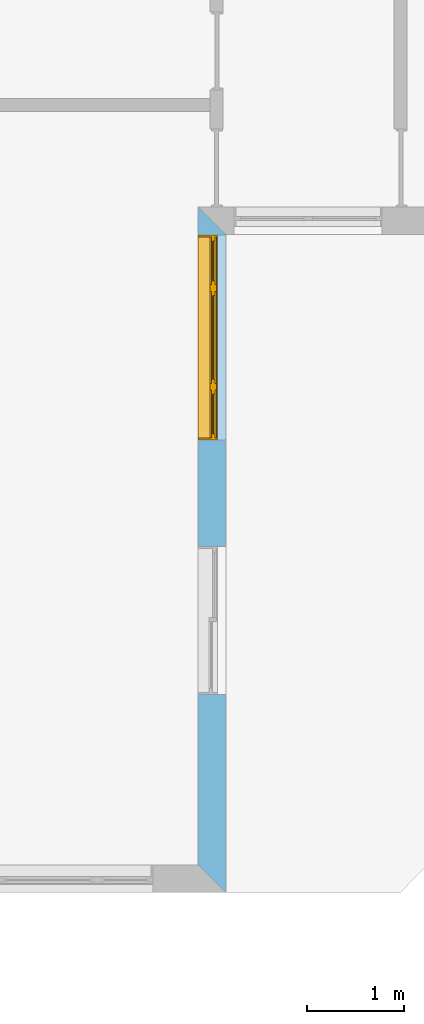
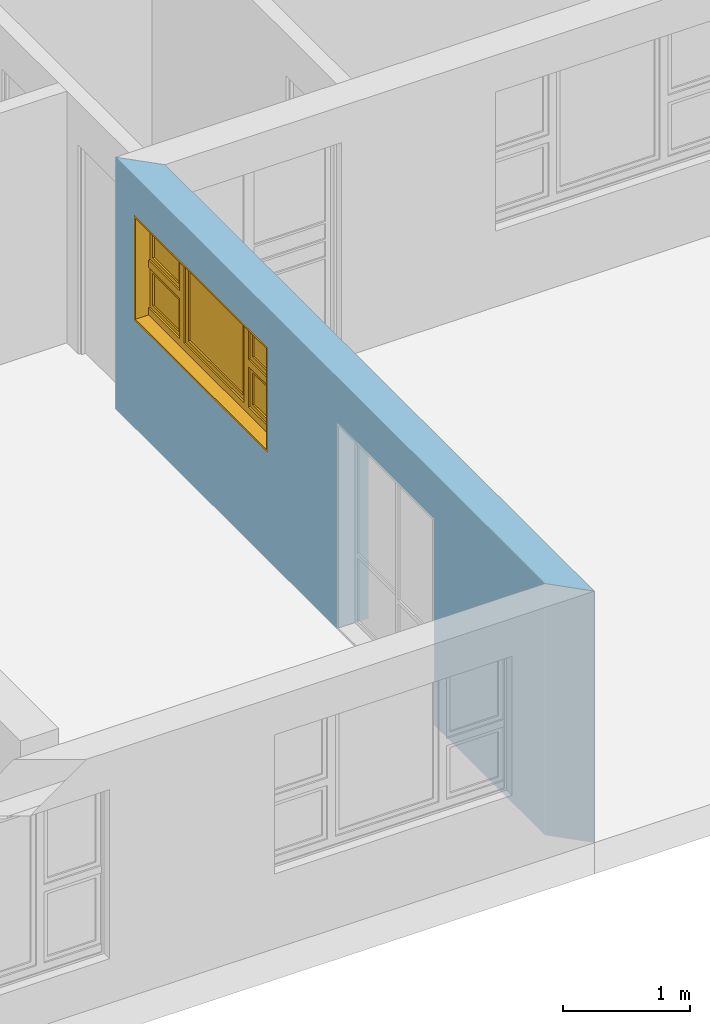
# One storey, part 10 of 15: 1 window, 2 openings, plus 1 element that does not belong to this part.
"""IFC4 building model written with IfcOpenShell, lengths in millimetres."""

from ifc_helpers import new_model, entity, si_unit, converted_unit, frame, origin_with_axes, origin_2d_with_axis, place, context, subcontext, project, spatial, line, indexed_curve, outline, extrude, clip, halfspace, polygons, source, transform, mapped, material, layer, layer_set, layer_usage, type_object, type_shapes, element, fill, save


model = new_model("IFC4")

# Units and contexts
model_context = context("Model", 3, precision=1e-05, world=origin_with_axes())
plan_context = context("Plan", 2, precision=1e-05, world=origin_2d_with_axis())
body_context = subcontext(model_context, "Body", "Model", "MODEL_VIEW")
ifc_project = project(units=[si_unit("VOLUMEUNIT", "CUBIC_METRE"), si_unit("LENGTHUNIT", "METRE", prefix="MILLI"), converted_unit("PLANEANGLEUNIT", "degree", entity("IfcReal", 0.0174532925199433), si_unit("PLANEANGLEUNIT", "RADIAN"), dimensions=[0, 0, 0, 0, 0, 0, 0]), si_unit("AREAUNIT", "SQUARE_METRE")], contexts=[model_context, plan_context])

# Site, building, storey
site_placement = place(None, origin_with_axes())
site = spatial("IfcSite", under=ifc_project, at=site_placement)
building_placement = place(site_placement, origin_with_axes())
building = spatial("IfcBuilding", under=site, at=building_placement, Name="Building")
storey_placement = place(building_placement, origin_with_axes())
storey = spatial("IfcBuildingStorey", under=building, at=storey_placement, Name="EXISTING")

# Wall, openings, window
ifc_material = material()
ifc_layer = layer(ifc_material, 285.0, Name="brick")
ifc_layer_set = layer_set([ifc_layer])
ifc_layer_usage = layer_usage(ifc_layer_set, "AXIS2", "POSITIVE", 0.0)
wall_type = type_object("IfcWallType", Name="285mm Wall", PredefinedType="STANDARD", material=ifc_layer_set)
wall_placement = place(storey_placement, frame((13494.119644165, -4518.33248138428, 0.0), z_axis=(0.0, 0.0, 1.0), x_axis=(3.13916473260163e-07, 0.999999999999951, 0.0)))
wall = element("IfcWall", 1, at=wall_placement, inside=storey, type_object=wall_type, material=ifc_layer_usage, Name="Wall", context=body_context, shape_type="Clipping", body=[
    clip(clip(extrude(outline(indexed_curve([(0.0, 0.0), (0.0, 285.0), (7060.00143769791, 285.0), (7060.00143769791, 0.0), (0.0, 0.0)], self_intersect=False)), origin_with_axes(), (0.0, 0.0, 1.0), 2425.00019073486), halfspace(frame((2.32475940720178e-05, 5.74426053390198e-05, 0.0), z_axis=(-0.707106709480286, 0.707106828689575, 0.0), x_axis=(0.707106840791191, 0.707106721581899, 0.0)), False)), halfspace(frame((6775.00104904175, 0.000276878381555434, 0.0), z_axis=(0.70710700750351, -0.707106530666351, 0.0), x_axis=(-0.707106542767924, -0.70710701960509, 0.0)), False)),
])
shared_shape_1 = source(origin_with_axes(), body_context, "Body", "SweptSolid", [
    extrude(outline(indexed_curve([(0.0, 0.0), (2110.00024414062, 0.0), (2110.00024414062, 1014.99993896484), (0.0, 1014.99993896484)], segments=[line(1, 2, 3, 4, 1)])), frame((1.19209282445354e-07, -600.0, 0.0), z_axis=(0.0, -1.0, 0.0), x_axis=(1.0, 0.0, 0.0)), (0.0, 0.0, -1.0), 1200.0),
])
opening_1_placement = place(wall_placement, frame((6771.17128867833, 136.111477694053, 1030.00009059906), z_axis=(0.0, 0.0, 1.0), x_axis=(-0.999999999999999, -3.17864987664478e-08, 0.0)))
opening_1 = element("IfcOpeningElement", 2, at=opening_1_placement, cuts=wall, PredefinedType="OPENING", context=body_context, shape_type="MappedRepresentation", body=[
    mapped(shared_shape_1, transform((0.0, 0.0, 0.0), x_axis=(1.0, 0.0, 0.0), y_axis=(0.0, 1.0, 0.0), z_axis=(0.0, 0.0, 1.0), scale=1.0)),
])
shared_shape_2 = source(origin_with_axes(), body_context, "Body", "SweptSolid", [
    extrude(outline(indexed_curve([(0.0, 0.0), (1525.00085449219, 0.0), (1525.00085449219, 1990.0), (0.0, 1990.0)], segments=[line(1, 2, 3, 4, 1)])), frame((-3.57627840230634e-07, -600.0, 0.0), z_axis=(0.0, -1.0, 0.0), x_axis=(1.0, 0.0, 0.0)), (0.0, 0.0, -1.0), 1200.0),
])
opening_2_placement = place(wall_placement, frame((3565.00013056336, 146.110700105945, 0.0), z_axis=(0.0, 0.0, 1.0), x_axis=(-0.999999999999999, -3.17864987664478e-08, 0.0)))
element("IfcOpeningElement", 3, at=opening_2_placement, cuts=wall, PredefinedType="OPENING", context=body_context, shape_type="MappedRepresentation", body=[
    mapped(shared_shape_2, transform((0.0, 0.0, 0.0), x_axis=(1.0, 0.0, 0.0), y_axis=(0.0, 1.0, 0.0), z_axis=(0.0, 0.0, 1.0), scale=1.0)),
])
window_type = type_object("IfcWindowType", Name="Ex.2110x1015", PartitioningType="NOTDEFINED", PredefinedType="WINDOW")
shared_shape_3 = source(origin_with_axes(), body_context, "Body", "Tessellation", [
    polygons([(2110.00048828125, -148.888916015625, 0.0), (2110.00048828125, -148.888916015625, 19.999979019165), (0.00107288348954171, -148.889038085938, 0.0), (0.00107288348954171, -148.889038085938, 19.999979019165), (2110.00048828125, 51.1110572814941, 0.0), (2110.00048828125, 51.1110572814941, 19.999979019165), (0.00107288348954171, 51.1110000610352, 0.0), (0.00107288348954171, 51.1110000610352, 19.999979019165), (2109.99951171875, -148.888916015625, 994.999694824219), (2109.99951171875, -148.888916015625, 1014.99993896484), (0.000119209282274824, -148.889038085938, 994.999694824219), (0.000119209282274824, -148.889038085938, 1014.99993896484), (2109.99951171875, 51.1110572814941, 994.999694824219), (2109.99951171875, 51.1110572814941, 1014.99993896484), (0.000119209282274824, 51.1110000610352, 994.999694824219), (0.000119209282274824, 51.1110000610352, 1014.99993896484), (0.000119209282274824, -148.888916015625, 20.0000400543213), (19.9996223449707, -148.888916015625, 20.0000400543213), (0.000119209282274824, -148.889038085938, 994.999694824219), (19.9996223449707, -148.889038085938, 994.999694824219), (0.000119209282274824, 51.1110572814941, 20.0000400543213), (19.9996223449707, 51.1110572814941, 20.0000400543213), (0.000119209282274824, 51.1110000610352, 994.999694824219), (19.9996223449707, 51.1110000610352, 994.999694824219), (2090.0, -148.888916015625, 20.0000400543213), (2109.99951171875, -148.888916015625, 20.0000400543213), (2090.0, -148.889038085938, 994.999694824219), (2109.99951171875, -148.889038085938, 994.999694824219), (2090.0, 51.1110572814941, 20.0000400543213), (2109.99951171875, 51.1111183166504, 20.0000400543213), (2090.0, 51.1110000610352, 994.999694824219), (2109.99951171875, 51.1110000610352, 994.999694824219), (1527.49926757812, -28.8889198303223, 20.0000400543213), (1597.49987792969, -28.8889198303223, 20.0000400543213), (1527.49926757812, -28.8889198303223, 994.999694824219), (1597.49987792969, -28.8889198303223, 994.999694824219), (1527.49926757812, 41.1110687255859, 20.0000400543213), (1597.49987792969, 41.1110687255859, 20.0000400543213), (1527.49926757812, 41.1110076904297, 994.999694824219), (1597.49987792969, 41.1110076904297, 994.999694824219), (512.500854492188, -28.8889198303223, 20.0000400543213), (582.500549316406, -28.8889198303223, 20.0000400543213), (512.500854492188, -28.8889198303223, 994.999694824219), (582.500549316406, -28.8889198303223, 994.999694824219), (512.500854492188, 41.1110687255859, 20.0000400543213), (582.500549316406, 41.1110687255859, 20.0000400543213), (512.500854492188, 41.1110076904297, 994.999694824219), (582.500549316406, 41.1110076904297, 994.999694824219), (19.9986686706543, -28.8890399932861, 549.998107910156), (19.9986686706543, -28.8889808654785, 479.998718261719), (512.499877929688, -28.8889198303223, 549.998840332031), (512.499877929688, -28.8889198303223, 479.999420166016), (19.9986686706543, 41.1109504699707, 549.998107910156), (19.9986686706543, 41.1110076904297, 479.998718261719), (512.499877929688, 41.1110687255859, 549.998840332031), (512.499877929688, 41.1110687255859, 479.999420166016), (1597.49987792969, -28.8890399932861, 549.998107910156), (1597.49987792969, -28.8889808654785, 479.998718261719), (2089.9990234375, -28.8889198303223, 549.998840332031), (2089.9990234375, -28.8889198303223, 479.999420166016), (1597.49987792969, 41.1109504699707, 549.998107910156), (1597.49987792969, 41.1110076904297, 479.998718261719), (2089.9990234375, 41.1110687255859, 549.998840332031), (2089.9990234375, 41.1110687255859, 479.999420166016), (1597.49987792969, -13.8889951705933, 994.999694824219), (1597.49987792969, -13.8889951705933, 955.0), (2089.9990234375, -13.8889360427856, 995.000183105469), (2089.9990234375, -13.8889360427856, 955.000671386719), (1597.49987792969, 26.1109638214111, 994.999694824219), (1597.49987792969, 26.1109638214111, 955.000244140625), (2089.9990234375, 26.1110229492188, 995.000183105469), (2089.9990234375, 26.111083984375, 955.000671386719), (1597.49987792969, -13.8889951705933, 589.997863769531), (1597.49987792969, -13.8889951705933, 549.998229980469), (2089.9990234375, -13.8889360427856, 589.998474121094), (2089.9990234375, -13.8889360427856, 549.998718261719), (1597.49987792969, 26.1109638214111, 589.997863769531), (1597.49987792969, 26.1109638214111, 549.998229980469), (2089.9990234375, 26.1110229492188, 589.998474121094), (2089.9990234375, 26.111083984375, 549.998718261719), (1637.49987792969, -13.8889360427856, 955.000244140625), (1597.50085449219, -13.8889360427856, 955.000244140625), (1637.49987792969, -13.8889360427856, 589.998474121094), (1597.50085449219, -13.8889360427856, 589.998474121094), (1637.49987792969, 26.1110229492188, 955.000244140625), (1597.50085449219, 26.1110229492188, 955.000244140625), (1637.49987792969, 26.111083984375, 589.998474121094), (1597.50085449219, 26.111083984375, 589.998474121094), (2089.9990234375, -13.8889360427856, 955.000244140625), (2050.0, -13.8889360427856, 955.000244140625), (2089.9990234375, -13.8889360427856, 589.998474121094), (2050.0, -13.8889360427856, 589.998474121094), (2089.9990234375, 26.1110229492188, 955.000244140625), (2050.0, 26.1110229492188, 955.000244140625), (2089.9990234375, 26.111083984375, 589.998474121094), (2050.0, 26.111083984375, 589.998474121094), (19.9986686706543, -13.8889951705933, 994.999694824219), (19.9986686706543, -13.8889951705933, 955.0), (512.499877929688, -13.8889360427856, 995.000183105469), (512.499877929688, -13.8889360427856, 955.000671386719), (19.9986686706543, 26.1109638214111, 994.999694824219), (19.9986686706543, 26.1109638214111, 955.000244140625), (512.499877929688, 26.1110229492188, 995.000183105469), (512.499877929688, 26.111083984375, 955.000671386719), (19.9986686706543, -13.8889951705933, 589.997863769531), (19.9986686706543, -13.8889951705933, 549.998229980469), (512.499877929688, -13.8889360427856, 589.998474121094), (512.499877929688, -13.8889360427856, 549.998718261719), (19.9986686706543, 26.1109638214111, 589.997863769531), (19.9986686706543, 26.1109638214111, 549.998229980469), (512.499877929688, 26.1110229492188, 589.998474121094), (512.499877929688, 26.111083984375, 549.998718261719), (60.0005340576172, -13.8889360427856, 955.000244140625), (20.0005760192871, -13.8889360427856, 955.000244140625), (60.0005340576172, -13.8889360427856, 589.998474121094), (20.0005760192871, -13.8889360427856, 589.998474121094), (60.0005340576172, 26.1110229492188, 955.000244140625), (20.0005760192871, 26.1110229492188, 955.000244140625), (60.0005340576172, 26.111083984375, 589.998474121094), (20.0005760192871, 26.111083984375, 589.998474121094), (512.500854492188, -13.8889360427856, 955.000244140625), (472.500885009766, -13.8889360427856, 955.000244140625), (512.500854492188, -13.8889360427856, 589.998474121094), (472.500885009766, -13.8889360427856, 589.998474121094), (512.500854492188, 26.1110229492188, 955.000244140625), (472.500885009766, 26.1110229492188, 955.000244140625), (512.500854492188, 26.111083984375, 589.998474121094), (472.500885009766, 26.111083984375, 589.998474121094), (19.9986686706543, -28.8890399932861, 89.9991912841797), (19.9986686706543, -28.8889808654785, 19.9997711181641), (512.499877929688, -28.8889198303223, 89.9999694824219), (512.499877929688, -28.8889198303223, 20.000545501709), (19.9986686706543, 41.1109504699707, 89.9991912841797), (19.9986686706543, 41.1110076904297, 19.9997711181641), (512.499877929688, 41.1110687255859, 90.0000305175781), (512.499877929688, 41.1110687255859, 20.0005760192871), (1597.49987792969, -28.8890399932861, 89.9991912841797), (1597.49987792969, -28.8889808654785, 19.9997711181641), (2089.9990234375, -28.8889198303223, 89.9999694824219), (2089.9990234375, -28.8889198303223, 20.000545501709), (1597.49987792969, 41.1109504699707, 89.9991912841797), (1597.49987792969, 41.1110076904297, 19.9997711181641), (2089.9990234375, 41.1110687255859, 90.0000305175781), (2089.9990234375, 41.1110687255859, 20.0005760192871), (582.499572753906, -28.8890399932861, 89.9991912841797), (582.499572753906, -28.8889808654785, 19.9997711181641), (1527.49926757812, -28.8889198303223, 89.9999694824219), (1527.49926757812, -28.8889198303223, 20.000545501709), (582.499572753906, 41.1109504699707, 89.9991912841797), (582.499572753906, 41.1110076904297, 19.9997711181641), (1527.49926757812, 41.1110687255859, 90.0000305175781), (1527.49926757812, 41.1110687255859, 20.0005760192871), (1597.49987792969, -13.8889951705933, 479.998931884766), (1597.49987792969, -13.8889951705933, 439.999237060547), (2089.9990234375, -13.8889360427856, 479.999420166016), (2089.9990234375, -13.8889360427856, 439.999816894531), (1597.49987792969, 26.1109638214111, 479.998931884766), (1597.49987792969, 26.1109638214111, 439.999237060547), (2089.9990234375, 26.1110229492188, 479.999420166016), (2089.9990234375, 26.111083984375, 439.999816894531), (1597.49987792969, -13.8889951705933, 129.999694824219), (1597.49987792969, -13.8889951705933, 90.0000305175781), (2089.9990234375, -13.8889360427856, 130.000228881836), (2089.9990234375, -13.8889360427856, 90.0005035400391), (1597.49987792969, 26.1109638214111, 129.999694824219), (1597.49987792969, 26.1109638214111, 90.0000305175781), (2089.9990234375, 26.1110229492188, 130.000228881836), (2089.9990234375, 26.111083984375, 90.0005645751953), (1637.49987792969, -13.8889360427856, 439.999816894531), (1597.50085449219, -13.8889360427856, 439.999816894531), (1637.49987792969, -13.8889360427856, 129.999099731445), (1597.50085449219, -13.8889360427856, 129.999145507812), (1637.49987792969, 26.1110229492188, 439.999816894531), (1597.50085449219, 26.1110229492188, 439.999816894531), (1637.49987792969, 26.111083984375, 129.999099731445), (1597.50085449219, 26.111083984375, 129.999145507812), (2089.9990234375, -13.8889360427856, 439.999816894531), (2050.0, -13.8889360427856, 439.999938964844), (2089.9990234375, -13.8889360427856, 129.999099731445), (2050.0, -13.8889360427856, 129.999145507812), (2089.9990234375, 26.1110229492188, 439.999816894531), (2050.0, 26.1110229492188, 439.999938964844), (2089.9990234375, 26.111083984375, 129.999099731445), (2050.0, 26.111083984375, 129.999145507812), (19.9986686706543, -13.8889951705933, 479.998931884766), (19.9986686706543, -13.8889951705933, 439.999237060547), (512.499877929688, -13.8889360427856, 479.999420166016), (512.499877929688, -13.8889360427856, 439.999816894531), (19.9986686706543, 26.1109638214111, 479.998931884766), (19.9986686706543, 26.1109638214111, 439.999237060547), (512.499877929688, 26.1110229492188, 479.999420166016), (512.499877929688, 26.111083984375, 439.999816894531), (19.9986686706543, -13.8889951705933, 129.998611450195), (19.9986686706543, -13.8889951705933, 89.9989547729492), (512.499877929688, -13.8889360427856, 129.999145507812), (512.499877929688, -13.8889360427856, 89.9994354248047), (19.9986686706543, 26.1109638214111, 129.998611450195), (19.9986686706543, 26.1109638214111, 89.9989547729492), (512.499877929688, 26.1110229492188, 129.999145507812), (512.499877929688, 26.111083984375, 89.9994888305664), (60.0005340576172, -13.8889360427856, 439.999816894531), (20.0005760192871, -13.8889360427856, 439.999938964844), (60.0005340576172, -13.8889360427856, 129.999099731445), (20.0005760192871, -13.8889360427856, 129.999145507812), (60.0005340576172, 26.1110229492188, 439.999816894531), (20.0005760192871, 26.1110229492188, 439.999938964844), (60.0005340576172, 26.111083984375, 129.999099731445), (20.0005760192871, 26.111083984375, 129.999145507812), (512.500854492188, -13.8889360427856, 439.999816894531), (472.500885009766, -13.8889360427856, 439.999816894531), (512.500854492188, -13.8889360427856, 129.999099731445), (472.500885009766, -13.8889360427856, 129.999145507812), (512.500854492188, 26.1110229492188, 439.999816894531), (472.500885009766, 26.1110229492188, 439.999816894531), (512.500854492188, 26.111083984375, 129.999099731445), (472.500885009766, 26.111083984375, 129.999145507812), (582.499572753906, -13.8889951705933, 994.999694824219), (582.499572753906, -13.8889951705933, 955.0), (1527.49926757812, -13.8889360427856, 995.000183105469), (1527.49926757812, -13.8889360427856, 955.000671386719), (582.499572753906, 26.1109638214111, 994.999694824219), (582.499572753906, 26.1109638214111, 955.000244140625), (1527.49926757812, 26.111083984375, 995.000183105469), (1527.49926757812, 26.111083984375, 955.000671386719), (582.499572753906, -13.8889951705933, 129.998916625977), (582.499572753906, -13.8889951705933, 89.9991912841797), (1527.49926757812, -13.8889360427856, 129.999450683594), (1527.49926757812, -13.8889360427856, 89.9997863769531), (582.499572753906, 26.1109638214111, 129.998916625977), (582.499572753906, 26.1109638214111, 89.9992523193359), (1527.49926757812, 26.111083984375, 129.999450683594), (1527.49926757812, 26.111083984375, 89.9997863769531), (622.50146484375, -13.8889360427856, 955.000244140625), (582.50146484375, -13.8889360427856, 955.000244140625), (622.50146484375, -13.8889360427856, 129.999694824219), (582.50146484375, -13.8889360427856, 129.999694824219), (622.50146484375, 26.1110229492188, 955.000244140625), (582.50146484375, 26.1110229492188, 955.000244140625), (622.50146484375, 26.111083984375, 129.999694824219), (582.50146484375, 26.111083984375, 129.999694824219), (1527.49926757812, -13.8889360427856, 955.000244140625), (1487.50024414062, -13.8889360427856, 955.000244140625), (1527.49926757812, -13.8889360427856, 129.999633789062), (1487.50024414062, -13.8889360427856, 129.999633789062), (1527.49926757812, 26.1110229492188, 955.000244140625), (1487.50024414062, 26.1110229492188, 955.000244140625), (1527.49926757812, 26.111083984375, 129.999633789062), (1487.50024414062, 26.111083984375, 129.999633789062), (1487.50122070312, 1.11104917526245, 955.000244140625), (622.502380371094, 1.11104917526245, 955.000244140625), (1487.50122070312, 1.11104917526245, 129.999633789062), (622.502380371094, 1.11104917526245, 129.999694824219), (1487.50122070312, 11.1110391616821, 955.000244140625), (622.502380371094, 11.1110391616821, 955.000244140625), (1487.50122070312, 11.1110391616821, 129.999633789062), (622.502380371094, 11.1110391616821, 129.999694824219), (2049.9990234375, 1.11104917526245, 955.000244140625), (1637.49987792969, 1.11104917526245, 955.000244140625), (2049.9990234375, 1.11104917526245, 589.998901367188), (1637.49987792969, 1.11104917526245, 589.998901367188), (2049.9990234375, 11.1110391616821, 955.000244140625), (1637.49987792969, 11.1110391616821, 955.000244140625), (2049.9990234375, 11.1110391616821, 589.998901367188), (1637.49987792969, 11.1110391616821, 589.998901367188), (2049.9990234375, 1.11104917526245, 439.999694824219), (1637.49987792969, 1.11104917526245, 439.999816894531), (2049.9990234375, 1.11104917526245, 130.000518798828), (1637.49987792969, 1.11104917526245, 130.000579833984), (2049.9990234375, 11.1110391616821, 439.999694824219), (1637.49987792969, 11.1110391616821, 439.999816894531), (2049.9990234375, 11.1110391616821, 130.000518798828), (1637.49987792969, 11.1110391616821, 130.000579833984), (472.499938964844, 1.11104917526245, 955.000244140625), (60.0005340576172, 1.11104917526245, 955.000244140625), (472.499938964844, 1.11104917526245, 589.998901367188), (60.0005340576172, 1.11104917526245, 589.998901367188), (472.499938964844, 11.1110391616821, 955.000244140625), (60.0005340576172, 11.1110391616821, 955.000244140625), (472.499938964844, 11.1110391616821, 589.998901367188), (60.0005340576172, 11.1110391616821, 589.998901367188), (472.499938964844, 1.11104917526245, 439.999694824219), (60.0005340576172, 1.11104917526245, 439.999694824219), (472.499938964844, 1.11104917526245, 130.000518798828), (60.0005340576172, 1.11104917526245, 130.000579833984), (472.499938964844, 11.1110391616821, 439.999694824219), (60.0005340576172, 11.1110391616821, 439.999694824219), (472.499938964844, 11.1110391616821, 130.000518798828), (60.0005340576172, 11.1110391616821, 130.000579833984)], [[[1, 2, 4, 3]], [[3, 4, 8, 7]], [[7, 8, 6, 5]], [[5, 6, 2, 1]], [[3, 7, 5, 1]], [[8, 4, 2, 6]], [[9, 10, 12, 11]], [[11, 12, 16, 15]], [[15, 16, 14, 13]], [[13, 14, 10, 9]], [[11, 15, 13, 9]], [[16, 12, 10, 14]], [[17, 18, 20, 19]], [[19, 20, 24, 23]], [[23, 24, 22, 21]], [[21, 22, 18, 17]], [[19, 23, 21, 17]], [[24, 20, 18, 22]], [[25, 26, 28, 27]], [[27, 28, 32, 31]], [[31, 32, 30, 29]], [[29, 30, 26, 25]], [[27, 31, 29, 25]], [[32, 28, 26, 30]], [[33, 34, 36, 35]], [[35, 36, 40, 39]], [[39, 40, 38, 37]], [[37, 38, 34, 33]], [[35, 39, 37, 33]], [[40, 36, 34, 38]], [[41, 42, 44, 43]], [[43, 44, 48, 47]], [[47, 48, 46, 45]], [[45, 46, 42, 41]], [[43, 47, 45, 41]], [[48, 44, 42, 46]], [[49, 50, 52, 51]], [[51, 52, 56, 55]], [[55, 56, 54, 53]], [[53, 54, 50, 49]], [[51, 55, 53, 49]], [[56, 52, 50, 54]], [[57, 58, 60, 59]], [[59, 60, 64, 63]], [[63, 64, 62, 61]], [[61, 62, 58, 57]], [[59, 63, 61, 57]], [[64, 60, 58, 62]], [[65, 66, 68, 67]], [[67, 68, 72, 71]], [[71, 72, 70, 69]], [[69, 70, 66, 65]], [[67, 71, 69, 65]], [[72, 68, 66, 70]], [[73, 74, 76, 75]], [[75, 76, 80, 79]], [[79, 80, 78, 77]], [[77, 78, 74, 73]], [[75, 79, 77, 73]], [[80, 76, 74, 78]], [[81, 82, 84, 83]], [[83, 84, 88, 87]], [[87, 88, 86, 85]], [[85, 86, 82, 81]], [[83, 87, 85, 81]], [[88, 84, 82, 86]], [[89, 90, 92, 91]], [[91, 92, 96, 95]], [[95, 96, 94, 93]], [[93, 94, 90, 89]], [[91, 95, 93, 89]], [[96, 92, 90, 94]], [[97, 98, 100, 99]], [[99, 100, 104, 103]], [[103, 104, 102, 101]], [[101, 102, 98, 97]], [[99, 103, 101, 97]], [[104, 100, 98, 102]], [[105, 106, 108, 107]], [[107, 108, 112, 111]], [[111, 112, 110, 109]], [[109, 110, 106, 105]], [[107, 111, 109, 105]], [[112, 108, 106, 110]], [[113, 114, 116, 115]], [[115, 116, 120, 119]], [[119, 120, 118, 117]], [[117, 118, 114, 113]], [[115, 119, 117, 113]], [[120, 116, 114, 118]], [[121, 122, 124, 123]], [[123, 124, 128, 127]], [[127, 128, 126, 125]], [[125, 126, 122, 121]], [[123, 127, 125, 121]], [[128, 124, 122, 126]], [[129, 130, 132, 131]], [[131, 132, 136, 135]], [[135, 136, 134, 133]], [[133, 134, 130, 129]], [[131, 135, 133, 129]], [[136, 132, 130, 134]], [[137, 138, 140, 139]], [[139, 140, 144, 143]], [[143, 144, 142, 141]], [[141, 142, 138, 137]], [[139, 143, 141, 137]], [[144, 140, 138, 142]], [[145, 146, 148, 147]], [[147, 148, 152, 151]], [[151, 152, 150, 149]], [[149, 150, 146, 145]], [[147, 151, 149, 145]], [[152, 148, 146, 150]], [[153, 154, 156, 155]], [[155, 156, 160, 159]], [[159, 160, 158, 157]], [[157, 158, 154, 153]], [[155, 159, 157, 153]], [[160, 156, 154, 158]], [[161, 162, 164, 163]], [[163, 164, 168, 167]], [[167, 168, 166, 165]], [[165, 166, 162, 161]], [[163, 167, 165, 161]], [[168, 164, 162, 166]], [[169, 170, 172, 171]], [[171, 172, 176, 175]], [[175, 176, 174, 173]], [[173, 174, 170, 169]], [[171, 175, 173, 169]], [[176, 172, 170, 174]], [[177, 178, 180, 179]], [[179, 180, 184, 183]], [[183, 184, 182, 181]], [[181, 182, 178, 177]], [[179, 183, 181, 177]], [[184, 180, 178, 182]], [[185, 186, 188, 187]], [[187, 188, 192, 191]], [[191, 192, 190, 189]], [[189, 190, 186, 185]], [[187, 191, 189, 185]], [[192, 188, 186, 190]], [[193, 194, 196, 195]], [[195, 196, 200, 199]], [[199, 200, 198, 197]], [[197, 198, 194, 193]], [[195, 199, 197, 193]], [[200, 196, 194, 198]], [[201, 202, 204, 203]], [[203, 204, 208, 207]], [[207, 208, 206, 205]], [[205, 206, 202, 201]], [[203, 207, 205, 201]], [[208, 204, 202, 206]], [[209, 210, 212, 211]], [[211, 212, 216, 215]], [[215, 216, 214, 213]], [[213, 214, 210, 209]], [[211, 215, 213, 209]], [[216, 212, 210, 214]], [[217, 218, 220, 219]], [[219, 220, 224, 223]], [[223, 224, 222, 221]], [[221, 222, 218, 217]], [[219, 223, 221, 217]], [[224, 220, 218, 222]], [[225, 226, 228, 227]], [[227, 228, 232, 231]], [[231, 232, 230, 229]], [[229, 230, 226, 225]], [[227, 231, 229, 225]], [[232, 228, 226, 230]], [[233, 234, 236, 235]], [[235, 236, 240, 239]], [[239, 240, 238, 237]], [[237, 238, 234, 233]], [[235, 239, 237, 233]], [[240, 236, 234, 238]], [[241, 242, 244, 243]], [[243, 244, 248, 247]], [[247, 248, 246, 245]], [[245, 246, 242, 241]], [[243, 247, 245, 241]], [[248, 244, 242, 246]], [[249, 250, 252, 251]], [[251, 252, 256, 255]], [[255, 256, 254, 253]], [[253, 254, 250, 249]], [[251, 255, 253, 249]], [[256, 252, 250, 254]], [[257, 258, 260, 259]], [[259, 260, 264, 263]], [[263, 264, 262, 261]], [[261, 262, 258, 257]], [[259, 263, 261, 257]], [[264, 260, 258, 262]], [[265, 266, 268, 267]], [[267, 268, 272, 271]], [[271, 272, 270, 269]], [[269, 270, 266, 265]], [[267, 271, 269, 265]], [[272, 268, 266, 270]], [[273, 274, 276, 275]], [[275, 276, 280, 279]], [[279, 280, 278, 277]], [[277, 278, 274, 273]], [[275, 279, 277, 273]], [[280, 276, 274, 278]], [[281, 282, 284, 283]], [[283, 284, 288, 287]], [[287, 288, 286, 285]], [[285, 286, 282, 281]], [[283, 287, 285, 281]], [[288, 284, 282, 286]]], closed=True),
])
type_shapes(window_type, [shared_shape_3])
window_placement = place(opening_1_placement, frame((0.000476837150209519, 1.52766688188422e-10, 0.0), z_axis=(0.0, 0.0, 1.0), x_axis=(0.999999999999983, -1.82782315505365e-07, 0.0)))
window = element("IfcWindow", 4, at=window_placement, inside=storey, type_object=window_type, Name="Window", context=body_context, shape_type="MappedRepresentation", body=[
    mapped(shared_shape_3, transform((0.0, 0.0, 0.0), x_axis=(1.0, 0.0, 0.0), y_axis=(0.0, 1.0, 0.0), z_axis=(0.0, 0.0, 1.0), scale=1.0)),
])
fill(opening_1, window)

save(model, "model.ifc")
